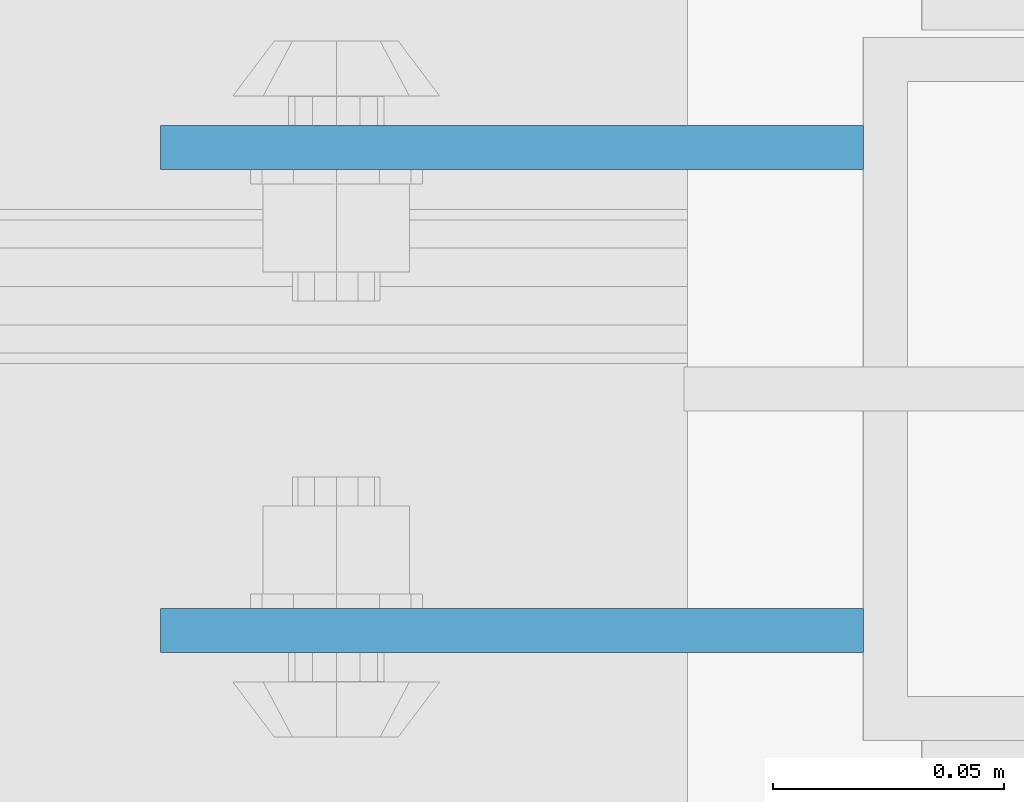
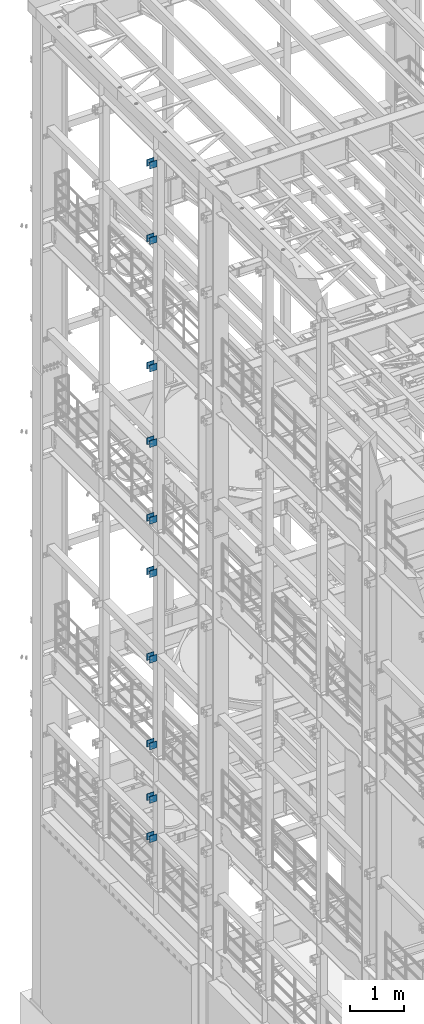
# One storey, part 1297 of 1876: 20 beams, 4 elements without a shape of their own.
"""IFC2X3 building model written with IfcOpenShell, lengths in millimetres."""

from ifc_helpers import new_model, si_unit, frame, origin_with_axes, place, context, subcontext, project, spatial, faceted_brep, material, type_object, element, aggregate, save


model = new_model("IFC2X3")

# Units and contexts
model_context = context("Model", 3, precision=1e-05, world=origin_with_axes())
body_context = subcontext(model_context, "Body", "Model", "MODEL_VIEW")
ifc_project = project(units=[si_unit("LENGTHUNIT", "METRE", prefix="MILLI"), si_unit("AREAUNIT", "SQUARE_METRE"), si_unit("VOLUMEUNIT", "CUBIC_METRE"), si_unit("MASSUNIT", "GRAM", prefix="KILO"), si_unit("TIMEUNIT", "SECOND"), si_unit("PLANEANGLEUNIT", "RADIAN"), si_unit("SOLIDANGLEUNIT", "STERADIAN"), si_unit("THERMODYNAMICTEMPERATUREUNIT", "DEGREE_CELSIUS"), si_unit("LUMINOUSINTENSITYUNIT", "LUMEN")], contexts=[model_context])

# Site, building, storey
site_placement = place(None, origin_with_axes())
site = spatial("IfcSite", under=ifc_project, at=site_placement, CompositionType="ELEMENT")
building_placement = place(site_placement, origin_with_axes())
building = spatial("IfcBuilding", under=site, at=building_placement, Name="Undefined", CompositionType="ELEMENT")
storey_placement = place(building_placement, origin_with_axes())
storey = spatial("IfcBuildingStorey", under=building, at=storey_placement, Name="Undefined", CompositionType="ELEMENT", Elevation=0.0)

# Assembly, beams
assembly_1_placement = place(storey_placement, origin_with_axes())
assembly_1 = element("IfcElementAssembly", 1, at=assembly_1_placement, inside=storey, Name="BEAM", AssemblyPlace="NOTDEFINED", PredefinedType="RIGID_FRAME")
ifc_material = material(Name="STEEL/A36")
beam_type = type_object("IfcBeamType", PredefinedType="NOTDEFINED")
beam_1_placement = place(assembly_1_placement, frame((-76.2000002548895, 9704.3875, 21678.9), z_axis=(0.0, 0.0, -1.0), x_axis=(-1.0, 0.0, 0.0)))
beam_1 = element("IfcBeam", 2, at=beam_1_placement, type_object=beam_type, material=ifc_material, Name="PLATE", context=body_context, shape_type="Brep", body=[
    faceted_brep([(0.0, 4.76249999999982, -76.1999999999998), (3.63797880709171e-12, 4.76249999999982, 76.1999969482422), (152.399993896484, 4.76250000000073, 76.1999969482422), (152.4, 4.76249999999982, -76.1999999999998), (3.63797880709171e-12, -4.76249999999982, 76.1999969482422), (152.399993896484, -4.76250000000073, 76.1999969482422), (0.0, -4.76249999999982, -76.1999999999998), (152.4, -4.76249999999982, -76.1999999999998)], [[[0, 1, 2, 3]], [[4, 5, 2, 1]], [[4, 6, 7, 5]], [[6, 0, 3, 7]], [[5, 7, 3, 2]], [[6, 4, 1, 0]]]),
])
beam_2_placement = place(assembly_1_placement, frame((-76.2000002548895, 9599.6125, 21678.9), z_axis=(0.0, 0.0, -1.0), x_axis=(-1.0, 0.0, 0.0)))
beam_2 = element("IfcBeam", 3, at=beam_2_placement, type_object=beam_type, material=ifc_material, Name="PLATE", context=body_context, shape_type="Brep", body=[
    faceted_brep([(0.0, 4.76249999999982, -76.1999999999998), (3.63797880709171e-12, 4.76249999999982, 76.1999969482422), (152.399993896484, 4.76250000000073, 76.1999969482422), (152.4, 4.76249999999982, -76.1999999999998), (3.63797880709171e-12, -4.76249999999982, 76.1999969482422), (152.399993896484, -4.76250000000073, 76.1999969482422), (0.0, -4.76249999999982, -76.1999999999998), (152.4, -4.76249999999982, -76.1999999999998)], [[[0, 1, 2, 3]], [[4, 5, 2, 1]], [[4, 6, 7, 5]], [[6, 0, 3, 7]], [[5, 7, 3, 2]], [[6, 4, 1, 0]]]),
])
beam_3_placement = place(assembly_1_placement, frame((-76.2000002548895, 9704.3875, 19958.05), z_axis=(0.0, 0.0, -1.0), x_axis=(-1.0, 0.0, 0.0)))
beam_3 = element("IfcBeam", 4, at=beam_3_placement, type_object=beam_type, material=ifc_material, Name="PLATE", context=body_context, shape_type="Brep", body=[
    faceted_brep([(0.0, 4.76249999999982, -76.1999999999998), (3.63797880709171e-12, 4.76249999999982, 76.1999969482422), (152.399993896484, 4.76250000000073, 76.1999969482422), (152.4, 4.76249999999982, -76.1999999999998), (3.63797880709171e-12, -4.76249999999982, 76.1999969482422), (152.399993896484, -4.76250000000073, 76.1999969482422), (0.0, -4.76249999999982, -76.1999999999998), (152.4, -4.76249999999982, -76.1999999999998)], [[[0, 1, 2, 3]], [[4, 5, 2, 1]], [[4, 6, 7, 5]], [[6, 0, 3, 7]], [[5, 7, 3, 2]], [[6, 4, 1, 0]]]),
])
beam_4_placement = place(assembly_1_placement, frame((-76.2000002548895, 9599.6125, 19958.05), z_axis=(0.0, 0.0, -1.0), x_axis=(-1.0, 0.0, 0.0)))
beam_4 = element("IfcBeam", 5, at=beam_4_placement, type_object=beam_type, material=ifc_material, Name="PLATE", context=body_context, shape_type="Brep", body=[
    faceted_brep([(0.0, 4.76249999999982, -76.1999999999998), (3.63797880709171e-12, 4.76249999999982, 76.1999969482422), (152.399993896484, 4.76250000000073, 76.1999969482422), (152.4, 4.76249999999982, -76.1999999999998), (3.63797880709171e-12, -4.76249999999982, 76.1999969482422), (152.399993896484, -4.76250000000073, 76.1999969482422), (0.0, -4.76249999999982, -76.1999999999998), (152.4, -4.76249999999982, -76.1999999999998)], [[[0, 1, 2, 3]], [[4, 5, 2, 1]], [[4, 6, 7, 5]], [[6, 0, 3, 7]], [[5, 7, 3, 2]], [[6, 4, 1, 0]]]),
])
aggregate(assembly_1, [beam_1, beam_2, beam_3, beam_4])

assembly_2_placement = place(storey_placement, origin_with_axes())
assembly_2 = element("IfcElementAssembly", 6, at=assembly_2_placement, inside=storey, Name="BEAM", AssemblyPlace="NOTDEFINED", PredefinedType="RIGID_FRAME")
beam_5_placement = place(assembly_2_placement, frame((-76.1999999999999, 9704.3875, 13589.0), z_axis=(0.0, 0.0, -1.0), x_axis=(-1.0, 0.0, 0.0)))
beam_5 = element("IfcBeam", 7, at=beam_5_placement, type_object=beam_type, material=ifc_material, Name="PLATE", context=body_context, shape_type="Brep", body=[
    faceted_brep([(0.0, 4.76249999999982, -76.1999999999998), (3.63797880709171e-12, 4.76249999999982, 76.1999969482422), (152.399993896484, 4.76250000000073, 76.1999969482422), (152.4, 4.76249999999982, -76.1999999999998), (3.63797880709171e-12, -4.76249999999982, 76.1999969482422), (152.399993896484, -4.76250000000073, 76.1999969482422), (0.0, -4.76249999999982, -76.1999999999998), (152.4, -4.76249999999982, -76.1999999999998)], [[[0, 1, 2, 3]], [[4, 5, 2, 1]], [[4, 6, 7, 5]], [[6, 0, 3, 7]], [[5, 7, 3, 2]], [[6, 4, 1, 0]]]),
])
beam_6_placement = place(assembly_2_placement, frame((-76.1999999999999, 9599.6125, 13589.0), z_axis=(0.0, 0.0, -1.0), x_axis=(-1.0, 0.0, 0.0)))
beam_6 = element("IfcBeam", 8, at=beam_6_placement, type_object=beam_type, material=ifc_material, Name="PLATE", context=body_context, shape_type="Brep", body=[
    faceted_brep([(0.0, 4.76249999999982, -76.1999999999998), (3.63797880709171e-12, 4.76249999999982, 76.1999969482422), (152.399993896484, 4.76250000000073, 76.1999969482422), (152.4, 4.76249999999982, -76.1999999999998), (3.63797880709171e-12, -4.76249999999982, 76.1999969482422), (152.399993896484, -4.76250000000073, 76.1999969482422), (0.0, -4.76249999999982, -76.1999999999998), (152.4, -4.76249999999982, -76.1999999999998)], [[[0, 1, 2, 3]], [[4, 5, 2, 1]], [[4, 6, 7, 5]], [[6, 0, 3, 7]], [[5, 7, 3, 2]], [[6, 4, 1, 0]]]),
])
beam_7_placement = place(assembly_2_placement, frame((-76.2, 9704.3875, 17056.1), z_axis=(0.0, 0.0, -1.0), x_axis=(-1.0, 0.0, 0.0)))
beam_7 = element("IfcBeam", 9, at=beam_7_placement, type_object=beam_type, material=ifc_material, Name="PLATE", context=body_context, shape_type="Brep", body=[
    faceted_brep([(0.0, 4.76249999999982, -76.1999999999998), (3.63797880709171e-12, 4.76249999999982, 76.1999969482422), (152.399993896484, 4.76250000000073, 76.1999969482422), (152.4, 4.76249999999982, -76.1999999999998), (3.63797880709171e-12, -4.76249999999982, 76.1999969482422), (152.399993896484, -4.76250000000073, 76.1999969482422), (0.0, -4.76249999999982, -76.1999999999998), (152.4, -4.76249999999982, -76.1999999999998)], [[[0, 1, 2, 3]], [[4, 5, 2, 1]], [[4, 6, 7, 5]], [[6, 0, 3, 7]], [[5, 7, 3, 2]], [[6, 4, 1, 0]]]),
])
beam_8_placement = place(assembly_2_placement, frame((-76.2, 9599.6125, 17056.1), z_axis=(0.0, 0.0, -1.0), x_axis=(-1.0, 0.0, 0.0)))
beam_8 = element("IfcBeam", 10, at=beam_8_placement, type_object=beam_type, material=ifc_material, Name="PLATE", context=body_context, shape_type="Brep", body=[
    faceted_brep([(0.0, 4.76249999999982, -76.1999999999998), (3.63797880709171e-12, 4.76249999999982, 76.1999969482422), (152.399993896484, 4.76250000000073, 76.1999969482422), (152.4, 4.76249999999982, -76.1999999999998), (3.63797880709171e-12, -4.76249999999982, 76.1999969482422), (152.399993896484, -4.76250000000073, 76.1999969482422), (0.0, -4.76249999999982, -76.1999999999998), (152.4, -4.76249999999982, -76.1999999999998)], [[[0, 1, 2, 3]], [[4, 5, 2, 1]], [[4, 6, 7, 5]], [[6, 0, 3, 7]], [[5, 7, 3, 2]], [[6, 4, 1, 0]]]),
])
beam_9_placement = place(assembly_2_placement, frame((-76.2, 9704.3875, 15335.25), z_axis=(0.0, 0.0, -1.0), x_axis=(-1.0, 0.0, 0.0)))
beam_9 = element("IfcBeam", 11, at=beam_9_placement, type_object=beam_type, material=ifc_material, Name="PLATE", context=body_context, shape_type="Brep", body=[
    faceted_brep([(0.0, 4.76249999999982, -76.1999999999998), (3.63797880709171e-12, 4.76249999999982, 76.1999969482422), (152.399993896484, 4.76250000000073, 76.1999969482422), (152.4, 4.76249999999982, -76.1999999999998), (3.63797880709171e-12, -4.76249999999982, 76.1999969482422), (152.399993896484, -4.76250000000073, 76.1999969482422), (0.0, -4.76249999999982, -76.1999999999998), (152.4, -4.76249999999982, -76.1999999999998)], [[[0, 1, 2, 3]], [[4, 5, 2, 1]], [[4, 6, 7, 5]], [[6, 0, 3, 7]], [[5, 7, 3, 2]], [[6, 4, 1, 0]]]),
])
beam_10_placement = place(assembly_2_placement, frame((-76.2, 9599.6125, 15335.25), z_axis=(0.0, 0.0, -1.0), x_axis=(-1.0, 0.0, 0.0)))
beam_10 = element("IfcBeam", 12, at=beam_10_placement, type_object=beam_type, material=ifc_material, Name="PLATE", context=body_context, shape_type="Brep", body=[
    faceted_brep([(0.0, 4.76249999999982, -76.1999999999998), (3.63797880709171e-12, 4.76249999999982, 76.1999969482422), (152.399993896484, 4.76250000000073, 76.1999969482422), (152.4, 4.76249999999982, -76.1999999999998), (3.63797880709171e-12, -4.76249999999982, 76.1999969482422), (152.399993896484, -4.76250000000073, 76.1999969482422), (0.0, -4.76249999999982, -76.1999999999998), (152.4, -4.76249999999982, -76.1999999999998)], [[[0, 1, 2, 3]], [[4, 5, 2, 1]], [[4, 6, 7, 5]], [[6, 0, 3, 7]], [[5, 7, 3, 2]], [[6, 4, 1, 0]]]),
])
aggregate(assembly_2, [beam_5, beam_6, beam_7, beam_8, beam_9, beam_10])

assembly_3_placement = place(storey_placement, origin_with_axes())
assembly_3 = element("IfcElementAssembly", 13, at=assembly_3_placement, inside=storey, Name="BEAM", AssemblyPlace="NOTDEFINED", PredefinedType="RIGID_FRAME")
beam_11_placement = place(assembly_3_placement, frame((-76.1999999999999, 9704.3875, 12369.8), z_axis=(0.0, 0.0, -1.0), x_axis=(-1.0, 0.0, 0.0)))
beam_11 = element("IfcBeam", 14, at=beam_11_placement, type_object=beam_type, material=ifc_material, Name="PLATE", context=body_context, shape_type="Brep", body=[
    faceted_brep([(0.0, 4.76249999999982, -76.1999999999998), (3.63797880709171e-12, 4.76249999999982, 76.1999969482422), (152.399993896484, 4.76250000000073, 76.1999969482422), (152.4, 4.76249999999982, -76.1999999999998), (3.63797880709171e-12, -4.76249999999982, 76.1999969482422), (152.399993896484, -4.76250000000073, 76.1999969482422), (0.0, -4.76249999999982, -76.1999999999998), (152.4, -4.76249999999982, -76.1999999999998)], [[[0, 1, 2, 3]], [[4, 5, 2, 1]], [[4, 6, 7, 5]], [[6, 0, 3, 7]], [[5, 7, 3, 2]], [[6, 4, 1, 0]]]),
])
beam_12_placement = place(assembly_3_placement, frame((-76.1999999999999, 9599.6125, 12369.8), z_axis=(0.0, 0.0, -1.0), x_axis=(-1.0, 0.0, 0.0)))
beam_12 = element("IfcBeam", 15, at=beam_12_placement, type_object=beam_type, material=ifc_material, Name="PLATE", context=body_context, shape_type="Brep", body=[
    faceted_brep([(0.0, 4.76249999999982, -76.1999999999998), (3.63797880709171e-12, 4.76249999999982, 76.1999969482422), (152.399993896484, 4.76250000000073, 76.1999969482422), (152.4, 4.76249999999982, -76.1999999999998), (3.63797880709171e-12, -4.76249999999982, 76.1999969482422), (152.399993896484, -4.76250000000073, 76.1999969482422), (0.0, -4.76249999999982, -76.1999999999998), (152.4, -4.76249999999982, -76.1999999999998)], [[[0, 1, 2, 3]], [[4, 5, 2, 1]], [[4, 6, 7, 5]], [[6, 0, 3, 7]], [[5, 7, 3, 2]], [[6, 4, 1, 0]]]),
])
beam_13_placement = place(assembly_3_placement, frame((-76.2, 9704.3875, 8445.5), z_axis=(0.0, 0.0, -1.0), x_axis=(-1.0, 0.0, 0.0)))
beam_13 = element("IfcBeam", 16, at=beam_13_placement, type_object=beam_type, material=ifc_material, Name="PLATE", context=body_context, shape_type="Brep", body=[
    faceted_brep([(0.0, 4.76249999999982, -76.1999999999998), (3.63797880709171e-12, 4.76249999999982, 76.1999969482422), (152.399993896484, 4.76250000000073, 76.1999969482422), (152.4, 4.76249999999982, -76.1999999999998), (3.63797880709171e-12, -4.76249999999982, 76.1999969482422), (152.399993896484, -4.76250000000073, 76.1999969482422), (0.0, -4.76249999999982, -76.1999999999998), (152.4, -4.76249999999982, -76.1999999999998)], [[[0, 1, 2, 3]], [[4, 5, 2, 1]], [[4, 6, 7, 5]], [[6, 0, 3, 7]], [[5, 7, 3, 2]], [[6, 4, 1, 0]]]),
])
beam_14_placement = place(assembly_3_placement, frame((-76.2, 9599.6125, 8445.5), z_axis=(0.0, 0.0, -1.0), x_axis=(-1.0, 0.0, 0.0)))
beam_14 = element("IfcBeam", 17, at=beam_14_placement, type_object=beam_type, material=ifc_material, Name="PLATE", context=body_context, shape_type="Brep", body=[
    faceted_brep([(0.0, 4.76249999999982, -76.1999999999998), (3.63797880709171e-12, 4.76249999999982, 76.1999969482422), (152.399993896484, 4.76250000000073, 76.1999969482422), (152.4, 4.76249999999982, -76.1999999999998), (3.63797880709171e-12, -4.76249999999982, 76.1999969482422), (152.399993896484, -4.76250000000073, 76.1999969482422), (0.0, -4.76249999999982, -76.1999999999998), (152.4, -4.76249999999982, -76.1999999999998)], [[[0, 1, 2, 3]], [[4, 5, 2, 1]], [[4, 6, 7, 5]], [[6, 0, 3, 7]], [[5, 7, 3, 2]], [[6, 4, 1, 0]]]),
])
beam_15_placement = place(assembly_3_placement, frame((-76.2, 9704.3875, 10420.35), z_axis=(0.0, 0.0, -1.0), x_axis=(-1.0, 0.0, 0.0)))
beam_15 = element("IfcBeam", 18, at=beam_15_placement, type_object=beam_type, material=ifc_material, Name="PLATE", context=body_context, shape_type="Brep", body=[
    faceted_brep([(0.0, 4.76249999999982, -76.1999999999998), (3.63797880709171e-12, 4.76249999999982, 76.1999969482422), (152.399993896484, 4.76250000000073, 76.1999969482422), (152.4, 4.76249999999982, -76.1999999999998), (3.63797880709171e-12, -4.76249999999982, 76.1999969482422), (152.399993896484, -4.76250000000073, 76.1999969482422), (0.0, -4.76249999999982, -76.1999999999998), (152.4, -4.76249999999982, -76.1999999999998)], [[[0, 1, 2, 3]], [[4, 5, 2, 1]], [[4, 6, 7, 5]], [[6, 0, 3, 7]], [[5, 7, 3, 2]], [[6, 4, 1, 0]]]),
])
beam_16_placement = place(assembly_3_placement, frame((-76.2, 9599.6125, 10420.35), z_axis=(0.0, 0.0, -1.0), x_axis=(-1.0, 0.0, 0.0)))
beam_16 = element("IfcBeam", 19, at=beam_16_placement, type_object=beam_type, material=ifc_material, Name="PLATE", context=body_context, shape_type="Brep", body=[
    faceted_brep([(0.0, 4.76249999999982, -76.1999999999998), (3.63797880709171e-12, 4.76249999999982, 76.1999969482422), (152.399993896484, 4.76250000000073, 76.1999969482422), (152.4, 4.76249999999982, -76.1999999999998), (3.63797880709171e-12, -4.76249999999982, 76.1999969482422), (152.399993896484, -4.76250000000073, 76.1999969482422), (0.0, -4.76249999999982, -76.1999999999998), (152.4, -4.76249999999982, -76.1999999999998)], [[[0, 1, 2, 3]], [[4, 5, 2, 1]], [[4, 6, 7, 5]], [[6, 0, 3, 7]], [[5, 7, 3, 2]], [[6, 4, 1, 0]]]),
])
aggregate(assembly_3, [beam_11, beam_12, beam_13, beam_14, beam_15, beam_16])

assembly_4_placement = place(storey_placement, origin_with_axes())
assembly_4 = element("IfcElementAssembly", 20, at=assembly_4_placement, inside=storey, Name="BEAM", AssemblyPlace="NOTDEFINED", PredefinedType="RIGID_FRAME")
beam_17_placement = place(assembly_4_placement, frame((-76.2, 9704.3875, 6330.95), z_axis=(0.0, 0.0, -1.0), x_axis=(-1.0, 0.0, 0.0)))
beam_17 = element("IfcBeam", 21, at=beam_17_placement, type_object=beam_type, material=ifc_material, Name="PLATE", context=body_context, shape_type="Brep", body=[
    faceted_brep([(0.0, 4.76249999999982, -76.1999999999998), (3.63797880709171e-12, 4.76249999999982, 76.1999969482422), (152.399993896484, 4.76250000000073, 76.1999969482422), (152.4, 4.76249999999982, -76.1999999999998), (3.63797880709171e-12, -4.76249999999982, 76.1999969482422), (152.399993896484, -4.76250000000073, 76.1999969482422), (0.0, -4.76249999999982, -76.1999999999998), (152.4, -4.76249999999982, -76.1999999999998)], [[[0, 1, 2, 3]], [[4, 5, 2, 1]], [[4, 6, 7, 5]], [[6, 0, 3, 7]], [[5, 7, 3, 2]], [[6, 4, 1, 0]]]),
])
beam_18_placement = place(assembly_4_placement, frame((-76.2, 9599.6125, 6330.95), z_axis=(0.0, 0.0, -1.0), x_axis=(-1.0, 0.0, 0.0)))
beam_18 = element("IfcBeam", 22, at=beam_18_placement, type_object=beam_type, material=ifc_material, Name="PLATE", context=body_context, shape_type="Brep", body=[
    faceted_brep([(0.0, 4.76249999999982, -76.1999999999998), (3.63797880709171e-12, 4.76249999999982, 76.1999969482422), (152.399993896484, 4.76250000000073, 76.1999969482422), (152.4, 4.76249999999982, -76.1999999999998), (3.63797880709171e-12, -4.76249999999982, 76.1999969482422), (152.399993896484, -4.76250000000073, 76.1999969482422), (0.0, -4.76249999999982, -76.1999999999998), (152.4, -4.76249999999982, -76.1999999999998)], [[[0, 1, 2, 3]], [[4, 5, 2, 1]], [[4, 6, 7, 5]], [[6, 0, 3, 7]], [[5, 7, 3, 2]], [[6, 4, 1, 0]]]),
])
beam_19_placement = place(assembly_4_placement, frame((-76.2, 9704.3875, 7226.3), z_axis=(0.0, 0.0, -1.0), x_axis=(-1.0, 0.0, 0.0)))
beam_19 = element("IfcBeam", 23, at=beam_19_placement, type_object=beam_type, material=ifc_material, Name="PLATE", context=body_context, shape_type="Brep", body=[
    faceted_brep([(0.0, 4.76249999999982, -76.1999999999998), (3.63797880709171e-12, 4.76249999999982, 76.1999969482422), (152.399993896484, 4.76250000000073, 76.1999969482422), (152.4, 4.76249999999982, -76.1999999999998), (3.63797880709171e-12, -4.76249999999982, 76.1999969482422), (152.399993896484, -4.76250000000073, 76.1999969482422), (0.0, -4.76249999999982, -76.1999999999998), (152.4, -4.76249999999982, -76.1999999999998)], [[[0, 1, 2, 3]], [[4, 5, 2, 1]], [[4, 6, 7, 5]], [[6, 0, 3, 7]], [[5, 7, 3, 2]], [[6, 4, 1, 0]]]),
])
beam_20_placement = place(assembly_4_placement, frame((-76.2, 9599.6125, 7226.3), z_axis=(0.0, 0.0, -1.0), x_axis=(-1.0, 0.0, 0.0)))
beam_20 = element("IfcBeam", 24, at=beam_20_placement, type_object=beam_type, material=ifc_material, Name="PLATE", context=body_context, shape_type="Brep", body=[
    faceted_brep([(0.0, 4.76249999999982, -76.1999999999998), (3.63797880709171e-12, 4.76249999999982, 76.1999969482422), (152.399993896484, 4.76250000000073, 76.1999969482422), (152.4, 4.76249999999982, -76.1999999999998), (3.63797880709171e-12, -4.76249999999982, 76.1999969482422), (152.399993896484, -4.76250000000073, 76.1999969482422), (0.0, -4.76249999999982, -76.1999999999998), (152.4, -4.76249999999982, -76.1999999999998)], [[[0, 1, 2, 3]], [[4, 5, 2, 1]], [[4, 6, 7, 5]], [[6, 0, 3, 7]], [[5, 7, 3, 2]], [[6, 4, 1, 0]]]),
])
aggregate(assembly_4, [beam_17, beam_18, beam_19, beam_20])

save(model, "model.ifc")
